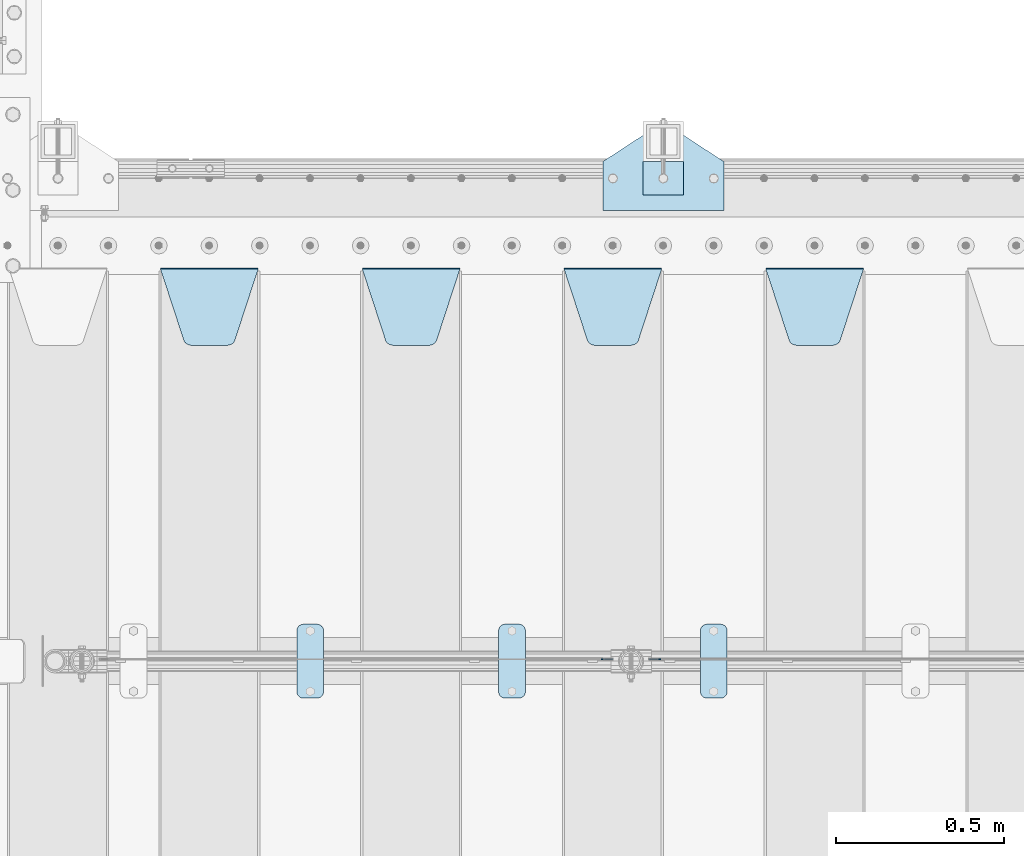
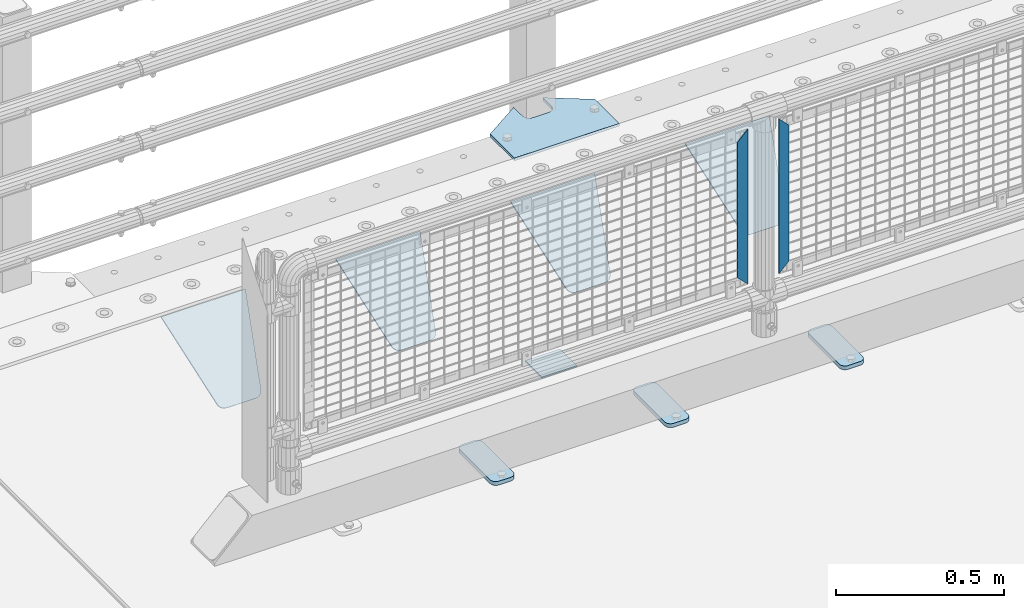
# One storey, part 230 of 270: 11 plates.
"""IFC2X3 building model written with IfcOpenShell, lengths in millimetres."""

from ifc_helpers import new_model, si_unit, frame, origin_with_axes, place, context, subcontext, project, spatial, faceted_brep, material, type_object, element, save


model = new_model("IFC2X3")

# Units and contexts
model_context = context("Model", 3, precision=1e-05, world=origin_with_axes())
body_context = subcontext(model_context, "Body", "Model", "MODEL_VIEW")
ifc_project = project(units=[si_unit("LENGTHUNIT", "METRE", prefix="MILLI"), si_unit("AREAUNIT", "SQUARE_METRE"), si_unit("VOLUMEUNIT", "CUBIC_METRE"), si_unit("MASSUNIT", "GRAM", prefix="KILO"), si_unit("TIMEUNIT", "SECOND"), si_unit("PLANEANGLEUNIT", "RADIAN"), si_unit("SOLIDANGLEUNIT", "STERADIAN"), si_unit("THERMODYNAMICTEMPERATUREUNIT", "DEGREE_CELSIUS"), si_unit("LUMINOUSINTENSITYUNIT", "LUMEN")], contexts=[model_context])

# Site, building, storey
site_placement = place(None, origin_with_axes())
site = spatial("IfcSite", under=ifc_project, at=site_placement, CompositionType="ELEMENT")
building_placement = place(site_placement, origin_with_axes())
building = spatial("IfcBuilding", under=site, at=building_placement, Name="Standard", CompositionType="ELEMENT")
storey_placement = place(building_placement, origin_with_axes())
storey = spatial("IfcBuildingStorey", under=building, at=storey_placement, Name="Undefined", CompositionType="ELEMENT", Elevation=0.0)

# Plates
ifc_material_1 = material(Name="STEEL/S355J2")
plate_type_1 = type_object("IfcPlateType", PredefinedType="NOTDEFINED")
plate_1_placement = place(storey_placement, frame((2170.0, -14995.0, 5.00000000004911), z_axis=(0.0, 1.0, 0.0), x_axis=(1.0, 0.0, 0.0)))
element("IfcPlate", 1, at=plate_1_placement, inside=storey, type_object=plate_type_1, material=ifc_material_1, context=body_context, shape_type="Brep", body=[
    faceted_brep([(0.0, -5.0, 0.0), (2.31396552408114e-06, -5.0, 145.0), (2.31396552408114e-06, 5.0, 145.0), (0.0, 5.0, 0.0), (130.0, -5.0, 230.0), (130.0, 5.0, 230.0), (130.0, -5.0, 180.0), (130.0, 5.0, 180.0), (130.48036798992, -5.0, 175.122741949597), (130.48036798992, 5.0, 175.122741949597), (131.903011687216, -5.0, 170.432914190873), (131.903011687216, 5.0, 170.432914190873), (134.213259692435, -5.0, 166.11074417451), (134.213259692435, 5.0, 166.11074417451), (137.322330470335, -5.0, 162.322330470337), (137.322330470335, 5.0, 162.322330470337), (141.110744174512, -5.0, 159.213259692437), (141.110744174512, 5.0, 159.213259692437), (145.432914190871, -5.0, 156.903011687218), (145.432914190871, 5.0, 156.903011687218), (150.122741949595, -5.0, 155.48036798992), (150.122741949595, 5.0, 155.48036798992), (155.0, -5.0, 155.0), (155.0, 5.0, 155.0), (205.0, -5.0, 155.0), (205.0, 5.0, 155.0), (209.877258050405, -5.0, 155.48036798992), (209.877258050405, 5.0, 155.48036798992), (214.567085809129, -5.0, 156.903011687218), (214.567085809129, 5.0, 156.903011687218), (218.889255825488, -5.0, 159.213259692437), (218.889255825488, 5.0, 159.213259692437), (222.677669529665, -5.0, 162.322330470337), (222.677669529665, 5.0, 162.322330470337), (225.786740307565, -5.0, 166.11074417451), (225.786740307565, 5.0, 166.11074417451), (228.096988312784, -5.0, 170.432914190873), (228.096988312784, 5.0, 170.432914190873), (229.51963201008, -5.0, 175.122741949597), (229.51963201008, 5.0, 175.122741949597), (230.0, -5.0, 180.0), (230.0, 5.0, 180.0), (230.0, -5.0, 230.0), (230.0, 5.0, 230.0), (360.0, -5.0, 145.0), (360.0, 5.0, 145.0), (360.0, -5.0, -7.27595761418343e-12), (360.0, 5.0, -7.27595761418343e-12)], [[[0, 1, 2, 3]], [[1, 4, 5, 2]], [[4, 6, 7, 5]], [[6, 8, 9, 7]], [[8, 10, 11, 9]], [[10, 12, 13, 11]], [[12, 14, 15, 13]], [[14, 16, 17, 15]], [[16, 18, 19, 17]], [[18, 20, 21, 19]], [[20, 22, 23, 21]], [[22, 24, 25, 23]], [[24, 26, 27, 25]], [[26, 28, 29, 27]], [[28, 30, 31, 29]], [[30, 32, 33, 31]], [[32, 34, 35, 33]], [[34, 36, 37, 35]], [[36, 38, 39, 37]], [[38, 40, 41, 39]], [[40, 42, 43, 41]], [[42, 44, 45, 43]], [[44, 46, 47, 45]], [[46, 0, 3, 47]], [[5, 7, 9, 11, 13, 15, 17, 19, 21, 23, 25, 27, 29, 31, 33, 35, 37, 39, 41, 43, 45, 47, 3, 2]], [[46, 44, 42, 40, 38, 36, 34, 32, 30, 28, 26, 24, 22, 20, 18, 16, 14, 12, 10, 8, 6, 4, 1, 0]]]),
])
plate_type_2 = type_object("IfcPlateType", PredefinedType="NOTDEFINED")
plate_2_placement = place(storey_placement, frame((2290.00000000014, -14949.9999999998, -857.500000000002), z_axis=(0.0, 1.0, 0.0), x_axis=(1.0, 0.0, 0.0)))
element("IfcPlate", 2, at=plate_2_placement, inside=storey, type_object=plate_type_2, material=ifc_material_1, context=body_context, shape_type="Brep", body=[
    faceted_brep([(0.0, -2.5, 0.0), (0.0, -2.5, 100.0), (0.0, 2.5, 100.0), (0.0, 2.5, 0.0), (120.0, -2.5, 100.0), (120.0, 2.5, 100.0), (120.0, -2.5, 0.0), (120.0, 2.5, 0.0)], [[[0, 1, 2, 3]], [[1, 4, 5, 2]], [[4, 6, 7, 5]], [[6, 0, 3, 7]], [[5, 7, 3, 2]], [[6, 4, 1, 0]]]),
])
plate_type_3 = type_object("IfcPlateType", PredefinedType="NOTDEFINED")
plate_3_placement = place(storey_placement, frame((2460.0, -16225.5, 21.0199999999977), z_axis=(1.0, 0.0, 0.0), x_axis=(0.0, -1.0, 0.0)))
element("IfcPlate", 3, at=plate_3_placement, inside=storey, type_object=plate_type_3, material=ifc_material_1, context=body_context, shape_type="Brep", body=[
    faceted_brep([(0.0, -7.0, 20.0), (0.0, -7.0, 60.0), (0.0, 7.0, 60.0), (0.0, 7.0, 20.0), (0.384294391937146, -7.0, 63.9018064403208), (0.384294391937146, 7.0, 63.9018064403208), (1.52240934977453, -7.0, 67.6536686473009), (1.52240934977453, 7.0, 67.6536686473009), (3.37060775395003, -7.0, 71.1114046603907), (3.37060775395003, 7.0, 71.1114046603907), (5.8578643762703, -7.0, 74.1421356237297), (5.8578643762703, 7.0, 74.1421356237297), (8.88859533960931, -7.0, 76.62939224605), (8.88859533960931, 7.0, 76.62939224605), (12.3463313526991, -7.0, 78.4775906502255), (12.3463313526991, 7.0, 78.4775906502255), (16.0981935596792, -7.0, 79.6157056080629), (16.0981935596792, 7.0, 79.6157056080629), (20.0, -7.0, 80.0), (20.0, 7.0, 80.0), (200.0, -7.0, 80.0), (200.0, 7.0, 80.0), (203.901806440321, -7.0, 79.6157056080629), (203.901806440321, 7.0, 79.6157056080629), (207.653668647301, -7.0, 78.4775906502255), (207.653668647301, 7.0, 78.4775906502255), (211.111404660391, -7.0, 76.62939224605), (211.111404660391, 7.0, 76.62939224605), (214.142135623733, -7.0, 74.1421356237297), (214.142135623733, 7.0, 74.1421356237297), (216.629392246054, -7.0, 71.1114046603907), (216.629392246054, 7.0, 71.1114046603907), (218.477590650225, -7.0, 67.6536686473009), (218.477590650225, 7.0, 67.6536686473009), (219.615705608063, -7.0, 63.9018064403208), (219.615705608063, 7.0, 63.9018064403208), (220.0, -7.0, 60.0), (220.0, 7.0, 60.0), (220.0, -7.0, 20.0), (220.0, 7.0, 20.0), (219.615705608063, -7.0, 16.0981935596792), (219.615705608063, 7.0, 16.0981935596792), (218.477590650225, -7.0, 12.3463313526991), (218.477590650225, 7.0, 12.3463313526991), (216.629392246054, -7.0, 8.88859533960931), (216.629392246054, 7.0, 8.88859533960931), (214.142135623733, -7.0, 5.8578643762703), (214.142135623733, 7.0, 5.8578643762703), (211.111404660391, -7.0, 3.37060775395003), (211.111404660391, 7.0, 3.37060775395003), (207.653668647301, -7.0, 1.52240934977453), (207.653668647301, 7.0, 1.52240934977453), (203.901806440321, -7.0, 0.384294391937146), (203.901806440321, 7.0, 0.384294391937146), (200.0, -7.0, 0.0), (200.0, 7.0, 0.0), (20.0, -7.0, 0.0), (20.0, 7.0, 0.0), (16.0981935596792, -7.0, 0.384294391937146), (16.0981935596792, 7.0, 0.384294391937146), (12.3463313526991, -7.0, 1.52240934977453), (12.3463313526991, 7.0, 1.52240934977453), (8.88859533960931, -7.0, 3.37060775395003), (8.88859533960931, 7.0, 3.37060775395003), (5.8578643762703, -7.0, 5.8578643762703), (5.8578643762703, 7.0, 5.8578643762703), (3.37060775395003, -7.0, 8.88859533960931), (3.37060775395003, 7.0, 8.88859533960931), (1.52240934977453, -7.0, 12.3463313526991), (1.52240934977453, 7.0, 12.3463313526991), (0.384294391937146, -7.0, 16.0981935596792), (0.384294391937146, 7.0, 16.0981935596792)], [[[0, 1, 2, 3]], [[1, 4, 5, 2]], [[4, 6, 7, 5]], [[6, 8, 9, 7]], [[8, 10, 11, 9]], [[10, 12, 13, 11]], [[12, 14, 15, 13]], [[14, 16, 17, 15]], [[16, 18, 19, 17]], [[18, 20, 21, 19]], [[20, 22, 23, 21]], [[22, 24, 25, 23]], [[24, 26, 27, 25]], [[26, 28, 29, 27]], [[28, 30, 31, 29]], [[30, 32, 33, 31]], [[32, 34, 35, 33]], [[34, 36, 37, 35]], [[36, 38, 39, 37]], [[38, 40, 41, 39]], [[40, 42, 43, 41]], [[42, 44, 45, 43]], [[44, 46, 47, 45]], [[46, 48, 49, 47]], [[48, 50, 51, 49]], [[50, 52, 53, 51]], [[52, 54, 55, 53]], [[54, 56, 57, 55]], [[56, 58, 59, 57]], [[58, 60, 61, 59]], [[60, 62, 63, 61]], [[62, 64, 65, 63]], [[64, 66, 67, 65]], [[66, 68, 69, 67]], [[68, 70, 71, 69]], [[70, 0, 3, 71]], [[5, 7, 9, 11, 13, 15, 17, 19, 21, 23, 25, 27, 29, 31, 33, 35, 37, 39, 41, 43, 45, 47, 49, 51, 53, 55, 57, 59, 61, 63, 65, 67, 69, 71, 3, 2]], [[70, 68, 66, 64, 62, 60, 58, 56, 54, 52, 50, 48, 46, 44, 42, 40, 38, 36, 34, 32, 30, 28, 26, 24, 22, 20, 18, 16, 14, 12, 10, 8, 6, 4, 1, 0]]]),
])
plate_4_placement = place(storey_placement, frame((1860.0, -16225.5, 21.0199999999977), z_axis=(1.0, 0.0, 0.0), x_axis=(0.0, -1.0, 0.0)))
element("IfcPlate", 4, at=plate_4_placement, inside=storey, type_object=plate_type_3, material=ifc_material_1, context=body_context, shape_type="Brep", body=[
    faceted_brep([(0.0, -7.0, 20.0), (0.0, -7.0, 60.0), (0.0, 7.0, 60.0), (0.0, 7.0, 20.0), (0.384294391937146, -7.0, 63.9018064403208), (0.384294391937146, 7.0, 63.9018064403208), (1.52240934977453, -7.0, 67.6536686473009), (1.52240934977453, 7.0, 67.6536686473009), (3.37060775395003, -7.0, 71.1114046603907), (3.37060775395003, 7.0, 71.1114046603907), (5.8578643762703, -7.0, 74.1421356237297), (5.8578643762703, 7.0, 74.1421356237297), (8.88859533960931, -7.0, 76.62939224605), (8.88859533960931, 7.0, 76.62939224605), (12.3463313526991, -7.0, 78.4775906502255), (12.3463313526991, 7.0, 78.4775906502255), (16.0981935596792, -7.0, 79.6157056080629), (16.0981935596792, 7.0, 79.6157056080629), (20.0, -7.0, 80.0), (20.0, 7.0, 80.0), (200.0, -7.0, 80.0), (200.0, 7.0, 80.0), (203.901806440321, -7.0, 79.6157056080629), (203.901806440321, 7.0, 79.6157056080629), (207.653668647301, -7.0, 78.4775906502255), (207.653668647301, 7.0, 78.4775906502255), (211.111404660391, -7.0, 76.62939224605), (211.111404660391, 7.0, 76.62939224605), (214.142135623733, -7.0, 74.1421356237297), (214.142135623733, 7.0, 74.1421356237297), (216.629392246054, -7.0, 71.1114046603907), (216.629392246054, 7.0, 71.1114046603907), (218.477590650225, -7.0, 67.6536686473009), (218.477590650225, 7.0, 67.6536686473009), (219.615705608063, -7.0, 63.9018064403208), (219.615705608063, 7.0, 63.9018064403208), (220.0, -7.0, 60.0), (220.0, 7.0, 60.0), (220.0, -7.0, 20.0), (220.0, 7.0, 20.0), (219.615705608063, -7.0, 16.0981935596792), (219.615705608063, 7.0, 16.0981935596792), (218.477590650225, -7.0, 12.3463313526991), (218.477590650225, 7.0, 12.3463313526991), (216.629392246054, -7.0, 8.88859533960931), (216.629392246054, 7.0, 8.88859533960931), (214.142135623733, -7.0, 5.8578643762703), (214.142135623733, 7.0, 5.8578643762703), (211.111404660391, -7.0, 3.37060775395003), (211.111404660391, 7.0, 3.37060775395003), (207.653668647301, -7.0, 1.52240934977453), (207.653668647301, 7.0, 1.52240934977453), (203.901806440321, -7.0, 0.384294391937146), (203.901806440321, 7.0, 0.384294391937146), (200.0, -7.0, 0.0), (200.0, 7.0, 0.0), (20.0, -7.0, 0.0), (20.0, 7.0, 0.0), (16.0981935596792, -7.0, 0.384294391937146), (16.0981935596792, 7.0, 0.384294391937146), (12.3463313526991, -7.0, 1.52240934977453), (12.3463313526991, 7.0, 1.52240934977453), (8.88859533960931, -7.0, 3.37060775395003), (8.88859533960931, 7.0, 3.37060775395003), (5.8578643762703, -7.0, 5.8578643762703), (5.8578643762703, 7.0, 5.8578643762703), (3.37060775395003, -7.0, 8.88859533960931), (3.37060775395003, 7.0, 8.88859533960931), (1.52240934977453, -7.0, 12.3463313526991), (1.52240934977453, 7.0, 12.3463313526991), (0.384294391937146, -7.0, 16.0981935596792), (0.384294391937146, 7.0, 16.0981935596792)], [[[0, 1, 2, 3]], [[1, 4, 5, 2]], [[4, 6, 7, 5]], [[6, 8, 9, 7]], [[8, 10, 11, 9]], [[10, 12, 13, 11]], [[12, 14, 15, 13]], [[14, 16, 17, 15]], [[16, 18, 19, 17]], [[18, 20, 21, 19]], [[20, 22, 23, 21]], [[22, 24, 25, 23]], [[24, 26, 27, 25]], [[26, 28, 29, 27]], [[28, 30, 31, 29]], [[30, 32, 33, 31]], [[32, 34, 35, 33]], [[34, 36, 37, 35]], [[36, 38, 39, 37]], [[38, 40, 41, 39]], [[40, 42, 43, 41]], [[42, 44, 45, 43]], [[44, 46, 47, 45]], [[46, 48, 49, 47]], [[48, 50, 51, 49]], [[50, 52, 53, 51]], [[52, 54, 55, 53]], [[54, 56, 57, 55]], [[56, 58, 59, 57]], [[58, 60, 61, 59]], [[60, 62, 63, 61]], [[62, 64, 65, 63]], [[64, 66, 67, 65]], [[66, 68, 69, 67]], [[68, 70, 71, 69]], [[70, 0, 3, 71]], [[5, 7, 9, 11, 13, 15, 17, 19, 21, 23, 25, 27, 29, 31, 33, 35, 37, 39, 41, 43, 45, 47, 49, 51, 53, 55, 57, 59, 61, 63, 65, 67, 69, 71, 3, 2]], [[70, 68, 66, 64, 62, 60, 58, 56, 54, 52, 50, 48, 46, 44, 42, 40, 38, 36, 34, 32, 30, 28, 26, 24, 22, 20, 18, 16, 14, 12, 10, 8, 6, 4, 1, 0]]]),
])
plate_5_placement = place(storey_placement, frame((1260.0, -16225.5, 21.0199999999977), z_axis=(1.0, 0.0, 0.0), x_axis=(0.0, -1.0, 0.0)))
element("IfcPlate", 5, at=plate_5_placement, inside=storey, type_object=plate_type_3, material=ifc_material_1, context=body_context, shape_type="Brep", body=[
    faceted_brep([(0.0, -7.0, 20.0), (0.0, -7.0, 60.0), (0.0, 7.0, 60.0), (0.0, 7.0, 20.0), (0.384294391937146, -7.0, 63.9018064403208), (0.384294391937146, 7.0, 63.9018064403208), (1.52240934977453, -7.0, 67.6536686473009), (1.52240934977453, 7.0, 67.6536686473009), (3.37060775395003, -7.0, 71.1114046603907), (3.37060775395003, 7.0, 71.1114046603907), (5.8578643762703, -7.0, 74.1421356237297), (5.8578643762703, 7.0, 74.1421356237297), (8.88859533960931, -7.0, 76.62939224605), (8.88859533960931, 7.0, 76.62939224605), (12.3463313526991, -7.0, 78.4775906502255), (12.3463313526991, 7.0, 78.4775906502255), (16.0981935596792, -7.0, 79.6157056080629), (16.0981935596792, 7.0, 79.6157056080629), (20.0, -7.0, 80.0), (20.0, 7.0, 80.0), (200.0, -7.0, 80.0), (200.0, 7.0, 80.0), (203.901806440321, -7.0, 79.6157056080629), (203.901806440321, 7.0, 79.6157056080629), (207.653668647301, -7.0, 78.4775906502255), (207.653668647301, 7.0, 78.4775906502255), (211.111404660391, -7.0, 76.62939224605), (211.111404660391, 7.0, 76.62939224605), (214.142135623733, -7.0, 74.1421356237297), (214.142135623733, 7.0, 74.1421356237297), (216.629392246054, -7.0, 71.1114046603907), (216.629392246054, 7.0, 71.1114046603907), (218.477590650225, -7.0, 67.6536686473009), (218.477590650225, 7.0, 67.6536686473009), (219.615705608063, -7.0, 63.9018064403208), (219.615705608063, 7.0, 63.9018064403208), (220.0, -7.0, 60.0), (220.0, 7.0, 60.0), (220.0, -7.0, 20.0), (220.0, 7.0, 20.0), (219.615705608063, -7.0, 16.0981935596792), (219.615705608063, 7.0, 16.0981935596792), (218.477590650225, -7.0, 12.3463313526991), (218.477590650225, 7.0, 12.3463313526991), (216.629392246054, -7.0, 8.88859533960931), (216.629392246054, 7.0, 8.88859533960931), (214.142135623733, -7.0, 5.8578643762703), (214.142135623733, 7.0, 5.8578643762703), (211.111404660391, -7.0, 3.37060775395003), (211.111404660391, 7.0, 3.37060775395003), (207.653668647301, -7.0, 1.52240934977453), (207.653668647301, 7.0, 1.52240934977453), (203.901806440321, -7.0, 0.384294391937146), (203.901806440321, 7.0, 0.384294391937146), (200.0, -7.0, 0.0), (200.0, 7.0, 0.0), (20.0, -7.0, 0.0), (20.0, 7.0, 0.0), (16.0981935596792, -7.0, 0.384294391937146), (16.0981935596792, 7.0, 0.384294391937146), (12.3463313526991, -7.0, 1.52240934977453), (12.3463313526991, 7.0, 1.52240934977453), (8.88859533960931, -7.0, 3.37060775395003), (8.88859533960931, 7.0, 3.37060775395003), (5.8578643762703, -7.0, 5.8578643762703), (5.8578643762703, 7.0, 5.8578643762703), (3.37060775395003, -7.0, 8.88859533960931), (3.37060775395003, 7.0, 8.88859533960931), (1.52240934977453, -7.0, 12.3463313526991), (1.52240934977453, 7.0, 12.3463313526991), (0.384294391937146, -7.0, 16.0981935596792), (0.384294391937146, 7.0, 16.0981935596792)], [[[0, 1, 2, 3]], [[1, 4, 5, 2]], [[4, 6, 7, 5]], [[6, 8, 9, 7]], [[8, 10, 11, 9]], [[10, 12, 13, 11]], [[12, 14, 15, 13]], [[14, 16, 17, 15]], [[16, 18, 19, 17]], [[18, 20, 21, 19]], [[20, 22, 23, 21]], [[22, 24, 25, 23]], [[24, 26, 27, 25]], [[26, 28, 29, 27]], [[28, 30, 31, 29]], [[30, 32, 33, 31]], [[32, 34, 35, 33]], [[34, 36, 37, 35]], [[36, 38, 39, 37]], [[38, 40, 41, 39]], [[40, 42, 43, 41]], [[42, 44, 45, 43]], [[44, 46, 47, 45]], [[46, 48, 49, 47]], [[48, 50, 51, 49]], [[50, 52, 53, 51]], [[52, 54, 55, 53]], [[54, 56, 57, 55]], [[56, 58, 59, 57]], [[58, 60, 61, 59]], [[60, 62, 63, 61]], [[62, 64, 65, 63]], [[64, 66, 67, 65]], [[66, 68, 69, 67]], [[68, 70, 71, 69]], [[70, 0, 3, 71]], [[5, 7, 9, 11, 13, 15, 17, 19, 21, 23, 25, 27, 29, 31, 33, 35, 37, 39, 41, 43, 45, 47, 49, 51, 53, 55, 57, 59, 61, 63, 65, 67, 69, 71, 3, 2]], [[70, 68, 66, 64, 62, 60, 58, 56, 54, 52, 50, 48, 46, 44, 42, 40, 38, 36, 34, 32, 30, 28, 26, 24, 22, 20, 18, 16, 14, 12, 10, 8, 6, 4, 1, 0]]]),
])
ifc_material_2 = material(Name="STEEL/S355N")
plate_type_4 = type_object("IfcPlateType", PredefinedType="NOTDEFINED")
plate_6_placement = place(storey_placement, frame((2655.0, -15168.2322330441, -1.76776695296576), z_axis=(0.0, -0.707106781186548, -0.707106781186547), x_axis=(1.0, 0.0, 0.0)))
element("IfcPlate", 6, at=plate_6_placement, inside=storey, type_object=plate_type_4, material=ifc_material_2, context=body_context, shape_type="Brep", body=[
    faceted_brep([(0.0, -2.5, 0.0), (69.345504679477, -2.5, 300.171731424831), (69.345504679477, 2.5, 300.171731424831), (0.0, 2.5, 0.0), (70.9274061199576, -2.5, 304.8974424154), (70.9274061199576, 2.5, 304.8974424154), (73.3818627772307, -2.49999999999818, 309.234538108527), (73.3818627772307, 2.50000000000182, 309.234538108527), (76.6187032999551, -2.5, 313.023683126103), (76.6187032999551, 2.5, 313.023683126103), (80.5190132704993, -2.5, 316.125672595372), (80.5190132704993, 2.50000000000182, 316.125672595372), (84.9395038596849, -2.49999999999818, 318.426546230476), (84.9395038596849, 2.5, 318.426546230476), (89.7177759439219, -2.49999999999818, 319.841774983275), (89.7177759439219, 2.50000000000182, 319.841774983275), (94.678286292652, -2.5, 320.319366455078), (94.678286292652, 2.5, 320.319366455078), (195.321713707348, -2.5, 320.319366455078), (195.321713707348, 2.5, 320.319366455078), (200.282224056078, -2.49999999999818, 319.841774983275), (200.282224056078, 2.50000000000182, 319.841774983275), (205.060496140315, -2.5, 318.426546230476), (205.060496140315, 2.5, 318.426546230476), (209.480986729501, -2.5, 316.12567259537), (209.480986729501, 2.50000000000182, 316.12567259537), (213.381296700045, -2.5, 313.023683126103), (213.381296700045, 2.5, 313.023683126103), (216.618137222769, -2.49999999999818, 309.234538108525), (216.618137222769, 2.50000000000182, 309.234538108527), (219.072593880042, -2.49999999999818, 304.897442415398), (219.072593880042, 2.50000000000182, 304.897442415397), (220.654495320523, -2.5, 300.171731424831), (220.654495320523, 2.5, 300.171731424831), (290.0, -2.49999999999818, 0.0), (290.0, 2.5, 0.0)], [[[0, 1, 2, 3]], [[1, 4, 5, 2]], [[4, 6, 7, 5]], [[6, 8, 9, 7]], [[8, 10, 11, 9]], [[10, 12, 13, 11]], [[12, 14, 15, 13]], [[14, 16, 17, 15]], [[16, 18, 19, 17]], [[18, 20, 21, 19]], [[20, 22, 23, 21]], [[22, 24, 25, 23]], [[24, 26, 27, 25]], [[26, 28, 29, 27]], [[28, 30, 31, 29]], [[30, 32, 33, 31]], [[32, 34, 35, 33]], [[34, 0, 3, 35]], [[5, 7, 9, 11, 13, 15, 17, 19, 21, 23, 25, 27, 29, 31, 33, 35, 3, 2]], [[34, 32, 30, 28, 26, 24, 22, 20, 18, 16, 14, 12, 10, 8, 6, 4, 1, 0]]]),
])
plate_7_placement = place(storey_placement, frame((2055.0, -15168.2322330441, -1.76776695296576), z_axis=(0.0, -0.707106781186548, -0.707106781186547), x_axis=(1.0, 0.0, 0.0)))
element("IfcPlate", 7, at=plate_7_placement, inside=storey, type_object=plate_type_4, material=ifc_material_2, context=body_context, shape_type="Brep", body=[
    faceted_brep([(0.0, -2.5, 0.0), (69.345504679477, -2.5, 300.171731424831), (69.345504679477, 2.5, 300.171731424831), (0.0, 2.5, 0.0), (70.9274061199576, -2.5, 304.8974424154), (70.9274061199576, 2.5, 304.8974424154), (73.3818627772307, -2.49999999999818, 309.234538108527), (73.3818627772307, 2.50000000000182, 309.234538108527), (76.6187032999551, -2.5, 313.023683126103), (76.6187032999551, 2.5, 313.023683126103), (80.5190132704993, -2.5, 316.125672595372), (80.5190132704993, 2.50000000000182, 316.125672595372), (84.9395038596849, -2.49999999999818, 318.426546230476), (84.9395038596849, 2.5, 318.426546230476), (89.7177759439219, -2.49999999999818, 319.841774983275), (89.7177759439219, 2.50000000000182, 319.841774983275), (94.678286292652, -2.5, 320.319366455078), (94.678286292652, 2.5, 320.319366455078), (195.321713707348, -2.5, 320.319366455078), (195.321713707348, 2.5, 320.319366455078), (200.282224056078, -2.49999999999818, 319.841774983275), (200.282224056078, 2.50000000000182, 319.841774983275), (205.060496140315, -2.5, 318.426546230476), (205.060496140315, 2.5, 318.426546230476), (209.480986729501, -2.5, 316.12567259537), (209.480986729501, 2.50000000000182, 316.12567259537), (213.381296700045, -2.5, 313.023683126103), (213.381296700045, 2.5, 313.023683126103), (216.618137222769, -2.49999999999818, 309.234538108525), (216.618137222769, 2.50000000000182, 309.234538108527), (219.072593880042, -2.49999999999818, 304.897442415398), (219.072593880042, 2.50000000000182, 304.897442415397), (220.654495320523, -2.5, 300.171731424831), (220.654495320523, 2.5, 300.171731424831), (290.0, -2.49999999999818, 0.0), (290.0, 2.5, 0.0)], [[[0, 1, 2, 3]], [[1, 4, 5, 2]], [[4, 6, 7, 5]], [[6, 8, 9, 7]], [[8, 10, 11, 9]], [[10, 12, 13, 11]], [[12, 14, 15, 13]], [[14, 16, 17, 15]], [[16, 18, 19, 17]], [[18, 20, 21, 19]], [[20, 22, 23, 21]], [[22, 24, 25, 23]], [[24, 26, 27, 25]], [[26, 28, 29, 27]], [[28, 30, 31, 29]], [[30, 32, 33, 31]], [[32, 34, 35, 33]], [[34, 0, 3, 35]], [[5, 7, 9, 11, 13, 15, 17, 19, 21, 23, 25, 27, 29, 31, 33, 35, 3, 2]], [[34, 32, 30, 28, 26, 24, 22, 20, 18, 16, 14, 12, 10, 8, 6, 4, 1, 0]]]),
])
plate_8_placement = place(storey_placement, frame((1455.0, -15168.2322330441, -1.76776695296576), z_axis=(0.0, -0.707106781186548, -0.707106781186547), x_axis=(1.0, 0.0, 0.0)))
element("IfcPlate", 8, at=plate_8_placement, inside=storey, type_object=plate_type_4, material=ifc_material_2, context=body_context, shape_type="Brep", body=[
    faceted_brep([(0.0, -2.5, 0.0), (69.345504679477, -2.5, 300.171731424831), (69.345504679477, 2.5, 300.171731424831), (0.0, 2.5, 0.0), (70.9274061199576, -2.5, 304.8974424154), (70.9274061199576, 2.5, 304.8974424154), (73.3818627772307, -2.49999999999818, 309.234538108527), (73.3818627772307, 2.50000000000182, 309.234538108527), (76.6187032999551, -2.5, 313.023683126103), (76.6187032999551, 2.5, 313.023683126103), (80.5190132704993, -2.5, 316.125672595372), (80.5190132704993, 2.50000000000182, 316.125672595372), (84.9395038596849, -2.49999999999818, 318.426546230476), (84.9395038596849, 2.5, 318.426546230476), (89.7177759439219, -2.49999999999818, 319.841774983275), (89.7177759439219, 2.50000000000182, 319.841774983275), (94.678286292652, -2.5, 320.319366455078), (94.678286292652, 2.5, 320.319366455078), (195.321713707348, -2.5, 320.319366455078), (195.321713707348, 2.5, 320.319366455078), (200.282224056078, -2.49999999999818, 319.841774983275), (200.282224056078, 2.50000000000182, 319.841774983275), (205.060496140315, -2.5, 318.426546230476), (205.060496140315, 2.5, 318.426546230476), (209.480986729501, -2.5, 316.12567259537), (209.480986729501, 2.50000000000182, 316.12567259537), (213.381296700045, -2.5, 313.023683126103), (213.381296700045, 2.5, 313.023683126103), (216.618137222769, -2.49999999999818, 309.234538108525), (216.618137222769, 2.50000000000182, 309.234538108527), (219.072593880042, -2.49999999999818, 304.897442415398), (219.072593880042, 2.50000000000182, 304.897442415397), (220.654495320523, -2.5, 300.171731424831), (220.654495320523, 2.5, 300.171731424831), (290.0, -2.49999999999818, 0.0), (290.0, 2.5, 0.0)], [[[0, 1, 2, 3]], [[1, 4, 5, 2]], [[4, 6, 7, 5]], [[6, 8, 9, 7]], [[8, 10, 11, 9]], [[10, 12, 13, 11]], [[12, 14, 15, 13]], [[14, 16, 17, 15]], [[16, 18, 19, 17]], [[18, 20, 21, 19]], [[20, 22, 23, 21]], [[22, 24, 25, 23]], [[24, 26, 27, 25]], [[26, 28, 29, 27]], [[28, 30, 31, 29]], [[30, 32, 33, 31]], [[32, 34, 35, 33]], [[34, 0, 3, 35]], [[5, 7, 9, 11, 13, 15, 17, 19, 21, 23, 25, 27, 29, 31, 33, 35, 3, 2]], [[34, 32, 30, 28, 26, 24, 22, 20, 18, 16, 14, 12, 10, 8, 6, 4, 1, 0]]]),
])
plate_9_placement = place(storey_placement, frame((855.0, -15168.2322330441, -1.76776695296576), z_axis=(0.0, -0.707106781186548, -0.707106781186547), x_axis=(1.0, 0.0, 0.0)))
element("IfcPlate", 9, at=plate_9_placement, inside=storey, type_object=plate_type_4, material=ifc_material_2, context=body_context, shape_type="Brep", body=[
    faceted_brep([(0.0, -2.5, 0.0), (69.345504679477, -2.5, 300.171731424831), (69.345504679477, 2.5, 300.171731424831), (0.0, 2.5, 0.0), (70.9274061199576, -2.5, 304.8974424154), (70.9274061199576, 2.5, 304.8974424154), (73.3818627772307, -2.49999999999818, 309.234538108527), (73.3818627772307, 2.50000000000182, 309.234538108527), (76.6187032999551, -2.5, 313.023683126103), (76.6187032999551, 2.5, 313.023683126103), (80.5190132704993, -2.5, 316.125672595372), (80.5190132704993, 2.50000000000182, 316.125672595372), (84.9395038596849, -2.49999999999818, 318.426546230476), (84.9395038596849, 2.5, 318.426546230476), (89.7177759439219, -2.49999999999818, 319.841774983275), (89.7177759439219, 2.50000000000182, 319.841774983275), (94.678286292652, -2.5, 320.319366455078), (94.678286292652, 2.5, 320.319366455078), (195.321713707348, -2.5, 320.319366455078), (195.321713707348, 2.5, 320.319366455078), (200.282224056078, -2.49999999999818, 319.841774983275), (200.282224056078, 2.50000000000182, 319.841774983275), (205.060496140315, -2.5, 318.426546230476), (205.060496140315, 2.5, 318.426546230476), (209.480986729501, -2.5, 316.12567259537), (209.480986729501, 2.50000000000182, 316.12567259537), (213.381296700045, -2.5, 313.023683126103), (213.381296700045, 2.5, 313.023683126103), (216.618137222769, -2.49999999999818, 309.234538108525), (216.618137222769, 2.50000000000182, 309.234538108527), (219.072593880042, -2.49999999999818, 304.897442415398), (219.072593880042, 2.50000000000182, 304.897442415397), (220.654495320523, -2.5, 300.171731424831), (220.654495320523, 2.5, 300.171731424831), (290.0, -2.49999999999818, 0.0), (290.0, 2.5, 0.0)], [[[0, 1, 2, 3]], [[1, 4, 5, 2]], [[4, 6, 7, 5]], [[6, 8, 9, 7]], [[8, 10, 11, 9]], [[10, 12, 13, 11]], [[12, 14, 15, 13]], [[14, 16, 17, 15]], [[16, 18, 19, 17]], [[18, 20, 21, 19]], [[20, 22, 23, 21]], [[22, 24, 25, 23]], [[24, 26, 27, 25]], [[26, 28, 29, 27]], [[28, 30, 31, 29]], [[30, 32, 33, 31]], [[32, 34, 35, 33]], [[34, 0, 3, 35]], [[5, 7, 9, 11, 13, 15, 17, 19, 21, 23, 25, 27, 29, 31, 33, 35, 3, 2]], [[34, 32, 30, 28, 26, 24, 22, 20, 18, 16, 14, 12, 10, 8, 6, 4, 1, 0]]]),
])
ifc_material_3 = material(Name="Misc_Undefined")
plate_type_5 = type_object("IfcPlateType", PredefinedType="NOTDEFINED")
plate_10_placement = place(storey_placement, frame((2342.50971354097, -16329.5, 879.519963133601), z_axis=(-0.707008801899319, 0.0, -0.707204746899291), x_axis=(-0.707204746899302, 0.0, 0.707008801899308)))
element("IfcPlate", 10, at=plate_10_placement, inside=storey, type_object=plate_type_5, material=ifc_material_3, context=body_context, shape_type="Brep", body=[
    faceted_brep([(0.0, -1.5, 0.0), (-348.552185058599, -1.5, 348.655029296877), (-348.552185058599, 1.5, 348.655029296877), (0.0, 1.5, 0.0), (-348.544891357427, -1.5, 398.152496337894), (-348.544891357427, 1.5, 398.152496337894), (49.50439453125, -1.5, 8.00355337560177e-11), (49.50439453125, 1.5, 8.00355337560177e-11)], [[[0, 1, 2, 3]], [[1, 4, 5, 2]], [[4, 6, 7, 5]], [[6, 0, 3, 7]], [[5, 7, 3, 2]], [[6, 4, 1, 0]]]),
])
plate_11_placement = place(storey_placement, frame((2165.49968748361, -16329.5, 879.52), z_axis=(0.707103624179499, 0.0, -0.707109938179501), x_axis=(0.707109938179513, 0.0, 0.707103624179487)))
element("IfcPlate", 11, at=plate_11_placement, inside=storey, type_object=plate_type_5, material=ifc_material_3, context=body_context, shape_type="Brep", body=[
    faceted_brep([(0.0, -1.5, 0.0), (-348.605163574224, -1.5, 348.602081298828), (-348.605163574224, 1.5, 348.602081298828), (0.0, 1.5, 0.0), (-348.605163574226, -1.5, 398.099334716795), (-348.605163574226, 1.5, 398.099334716795), (49.4976959228497, -1.5, -7.27595761418343e-12), (49.4976959228497, 1.5, -7.27595761418343e-12)], [[[0, 1, 2, 3]], [[1, 4, 5, 2]], [[4, 6, 7, 5]], [[6, 0, 3, 7]], [[5, 7, 3, 2]], [[6, 4, 1, 0]]]),
])

save(model, "model.ifc")
